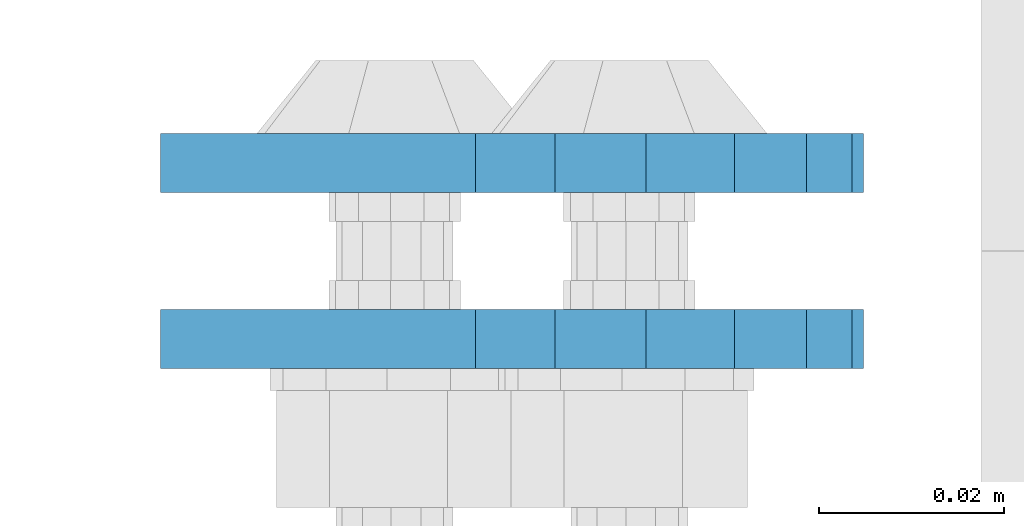
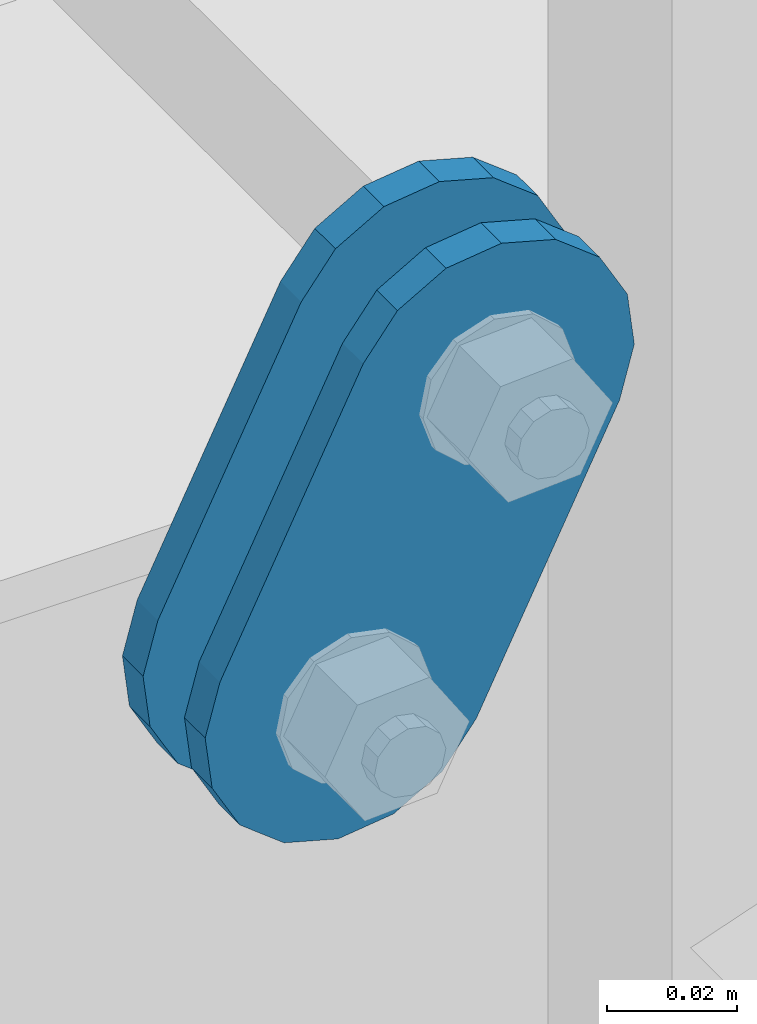
# One storey, part 1688 of 1876: 2 plates, 2 elements without a shape of their own.
"""IFC2X3 building model written with IfcOpenShell, lengths in millimetres."""

from ifc_helpers import new_model, si_unit, frame, origin_with_axes, place, context, subcontext, project, spatial, faceted_brep, material, type_object, element, aggregate, save


model = new_model("IFC2X3")

# Units and contexts
model_context = context("Model", 3, precision=1e-05, world=origin_with_axes())
body_context = subcontext(model_context, "Body", "Model", "MODEL_VIEW")
ifc_project = project(units=[si_unit("LENGTHUNIT", "METRE", prefix="MILLI"), si_unit("AREAUNIT", "SQUARE_METRE"), si_unit("VOLUMEUNIT", "CUBIC_METRE"), si_unit("MASSUNIT", "GRAM", prefix="KILO"), si_unit("TIMEUNIT", "SECOND"), si_unit("PLANEANGLEUNIT", "RADIAN"), si_unit("SOLIDANGLEUNIT", "STERADIAN"), si_unit("THERMODYNAMICTEMPERATUREUNIT", "DEGREE_CELSIUS"), si_unit("LUMINOUSINTENSITYUNIT", "LUMEN")], contexts=[model_context])

# Site, building, storey
site_placement = place(None, origin_with_axes())
site = spatial("IfcSite", under=ifc_project, at=site_placement, CompositionType="ELEMENT")
building_placement = place(site_placement, origin_with_axes())
building = spatial("IfcBuilding", under=site, at=building_placement, Name="Undefined", CompositionType="ELEMENT")
storey_placement = place(building_placement, origin_with_axes())
storey = spatial("IfcBuildingStorey", under=building, at=storey_placement, Name="Undefined", CompositionType="ELEMENT", Elevation=0.0)

# Assembly, plate
assembly_1_placement = place(storey_placement, origin_with_axes())
assembly_1 = element("IfcElementAssembly", 1, at=assembly_1_placement, inside=storey, Name="PLATE", AssemblyPlace="NOTDEFINED", PredefinedType="RIGID_FRAME")
ifc_material = material(Name="STEEL/A36")
plate_type = type_object("IfcPlateType", PredefinedType="NOTDEFINED")
plate_1_placement = place(assembly_1_placement, frame((-354.259224851121, 7610.47500303177, 7895.37767748094), z_axis=(0.894427191199916, 0.0, -0.447213595099958), x_axis=(-0.447213595099961, 6.99999707257306e-09, -0.894427191199915)))
plate_1 = element("IfcPlate", 2, at=plate_1_placement, type_object=plate_type, material=ifc_material, Name="PLATE", context=body_context, shape_type="Brep", body=[
    faceted_brep([(-8.59611645864788e-07, -3.17499999999654, 25.3999987589127), (1.93345873884391, -3.17499999999382, 35.1201580589886), (1.93345873884391, 3.17500000000564, 35.1201580589886), (-8.59611645864788e-07, 3.17500000000382, 25.3999987589132), (7.43948648259902, -3.17499999999109, 43.3605112870105), (7.43948648259902, 3.17500000000928, 43.3605112870105), (15.6798395242777, -3.17499999998654, 48.8665393096448), (15.6798395242777, 3.17500000001382, 48.8665393096448), (25.3999987589095, -3.17499999998199, 50.7999992370592), (25.3999987589095, 3.17500000001837, 50.7999992370592), (82.196130752618, -3.17499999998381, 50.7999992370605), (82.196130752618, 3.17500000001655, 50.7999992370642), (91.9162897887145, -3.17499999997926, 48.8665393918873), (91.9162897887145, 3.1750000000211, 48.8665393918909), (100.156642725027, -3.17499999997472, 43.3605115909359), (100.156642725027, 3.17500000002565, 43.3605115909395), (105.662670525982, -3.17499999997108, 35.1201586546285), (105.662670525986, 3.17500000002929, 35.1201586546358), (107.596130371159, -3.17499999996744, 25.3999996185757), (107.596130371159, 3.17500000003292, 25.3999996185794), (105.662670525981, -3.17499999996471, 15.6798405824902), (105.662670525981, 3.17500000003565, 15.6798405824939), (100.156642725024, -3.17499999996471, 7.43948764618654), (100.156642725025, 3.17500000003565, 7.43948764619017), (91.9162897887127, -3.17499999996562, 1.93345984522784), (91.9162897887127, 3.17500000003474, 1.93345984523148), (82.196130752618, -3.17499999996835, 4.54747350886464e-11), (82.196130752618, 3.1750000000311, 4.91127138957381e-11), (25.399998758905, -3.17499999999018, -8.64019966684282e-12), (25.399998758905, 3.17500000001019, -8.64019966684282e-12), (15.679839921364, -3.17499999999382, 1.9334597629304), (15.679839921364, 3.17500000000655, 1.9334597629304), (7.43948709043525, -3.17499999999654, 7.43948734220839), (7.43948709043525, 3.17500000000382, 7.43948734220885), (1.93345923228208, -3.17499999999654, 15.6798399868012), (1.93345923228208, 3.17500000000291, 15.6798399868012)], [[[0, 1, 2, 3]], [[1, 4, 5, 2]], [[4, 6, 7, 5]], [[6, 8, 9, 7]], [[8, 10, 11, 9]], [[10, 12, 13, 11]], [[12, 14, 15, 13]], [[14, 16, 17, 15]], [[16, 18, 19, 17]], [[18, 20, 21, 19]], [[20, 22, 23, 21]], [[22, 24, 25, 23]], [[24, 26, 27, 25]], [[26, 28, 29, 27]], [[28, 30, 31, 29]], [[30, 32, 33, 31]], [[32, 34, 35, 33]], [[34, 0, 3, 35]], [[5, 7, 9, 11, 13, 15, 17, 19, 21, 23, 25, 27, 29, 31, 33, 35, 3, 2]], [[34, 32, 30, 28, 26, 24, 22, 20, 18, 16, 14, 12, 10, 8, 6, 4, 1, 0]]]),
])
aggregate(assembly_1, [plate_1])

assembly_2_placement = place(storey_placement, origin_with_axes())
assembly_2 = element("IfcElementAssembly", 3, at=assembly_2_placement, inside=storey, Name="PLATE", AssemblyPlace="NOTDEFINED", PredefinedType="RIGID_FRAME")
plate_2_placement = place(assembly_2_placement, frame((-354.259224851121, 7629.53619933645, 7895.37767748094), z_axis=(0.894427191199916, 0.0, -0.447213595099958), x_axis=(-0.447213595099961, 6.99999707257306e-09, -0.894427191199915)))
plate_2 = element("IfcPlate", 4, at=plate_2_placement, type_object=plate_type, material=ifc_material, Name="PLATE", context=body_context, shape_type="Brep", body=[
    faceted_brep([(-8.59611645864788e-07, -3.17499999999654, 25.3999987589127), (1.93345873884391, -3.17499999999382, 35.1201580589886), (1.93345873884391, 3.17500000000564, 35.1201580589886), (-8.59611645864788e-07, 3.17500000000382, 25.3999987589132), (7.43948648259902, -3.17499999999109, 43.3605112870105), (7.43948648259902, 3.17500000000928, 43.3605112870105), (15.6798395242777, -3.17499999998654, 48.8665393096448), (15.6798395242777, 3.17500000001382, 48.8665393096448), (25.3999987589095, -3.17499999998199, 50.7999992370592), (25.3999987589095, 3.17500000001837, 50.7999992370592), (82.196130752618, -3.17499999998381, 50.7999992370605), (82.196130752618, 3.17500000001655, 50.7999992370642), (91.9162897887145, -3.17499999997926, 48.8665393918873), (91.9162897887145, 3.1750000000211, 48.8665393918909), (100.156642725027, -3.17499999997472, 43.3605115909359), (100.156642725027, 3.17500000002565, 43.3605115909395), (105.662670525982, -3.17499999997108, 35.1201586546285), (105.662670525986, 3.17500000002929, 35.1201586546358), (107.596130371159, -3.17499999996744, 25.3999996185757), (107.596130371159, 3.17500000003292, 25.3999996185794), (105.662670525981, -3.17499999996471, 15.6798405824902), (105.662670525981, 3.17500000003565, 15.6798405824939), (100.156642725024, -3.17499999996471, 7.43948764618654), (100.156642725025, 3.17500000003565, 7.43948764619017), (91.9162897887127, -3.17499999996562, 1.93345984522784), (91.9162897887127, 3.17500000003474, 1.93345984523148), (82.196130752618, -3.17499999996835, 4.54747350886464e-11), (82.196130752618, 3.1750000000311, 4.91127138957381e-11), (25.399998758905, -3.17499999999018, -8.64019966684282e-12), (25.399998758905, 3.17500000001019, -8.64019966684282e-12), (15.679839921364, -3.17499999999382, 1.9334597629304), (15.679839921364, 3.17500000000655, 1.9334597629304), (7.43948709043525, -3.17499999999654, 7.43948734220839), (7.43948709043525, 3.17500000000382, 7.43948734220885), (1.93345923228208, -3.17499999999654, 15.6798399868012), (1.93345923228208, 3.17500000000291, 15.6798399868012)], [[[0, 1, 2, 3]], [[1, 4, 5, 2]], [[4, 6, 7, 5]], [[6, 8, 9, 7]], [[8, 10, 11, 9]], [[10, 12, 13, 11]], [[12, 14, 15, 13]], [[14, 16, 17, 15]], [[16, 18, 19, 17]], [[18, 20, 21, 19]], [[20, 22, 23, 21]], [[22, 24, 25, 23]], [[24, 26, 27, 25]], [[26, 28, 29, 27]], [[28, 30, 31, 29]], [[30, 32, 33, 31]], [[32, 34, 35, 33]], [[34, 0, 3, 35]], [[5, 7, 9, 11, 13, 15, 17, 19, 21, 23, 25, 27, 29, 31, 33, 35, 3, 2]], [[34, 32, 30, 28, 26, 24, 22, 20, 18, 16, 14, 12, 10, 8, 6, 4, 1, 0]]]),
])
aggregate(assembly_2, [plate_2])

save(model, "model.ifc")
